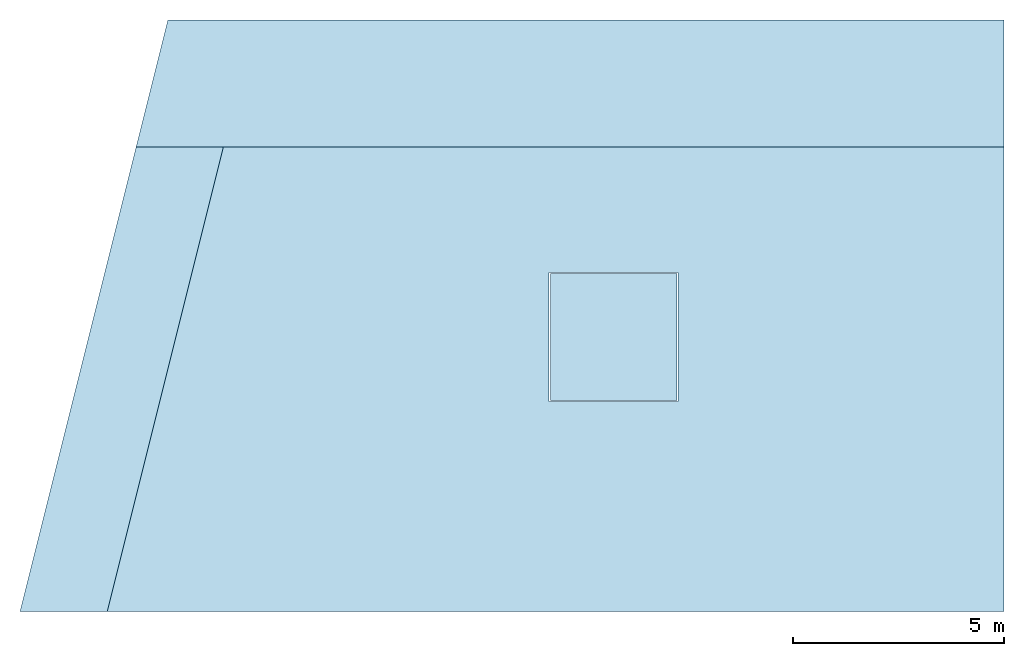
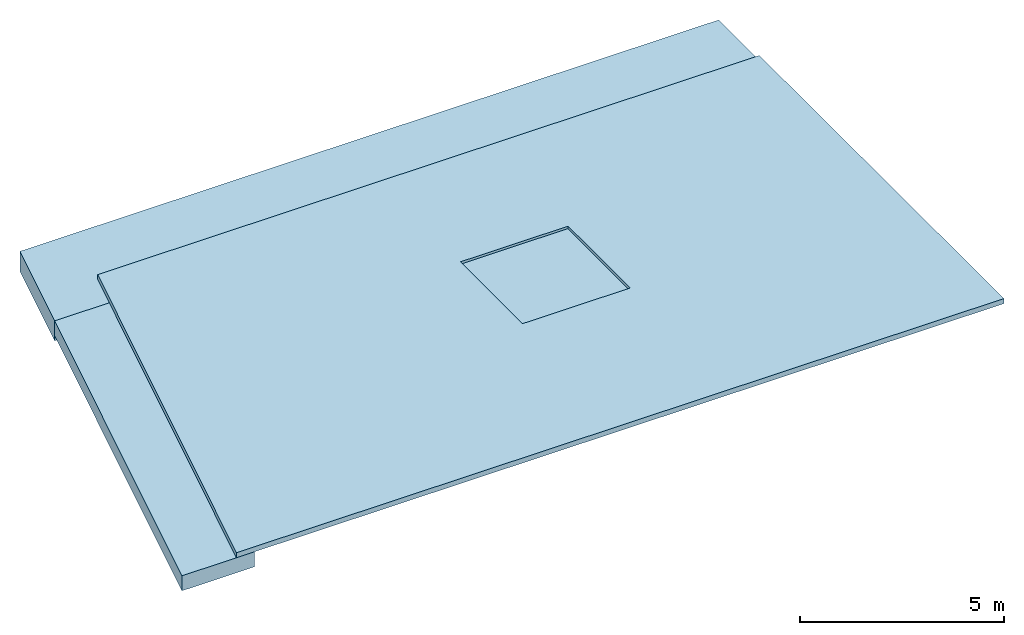
# One storey: 4 plates, 1 opening, 4 elements without a shape of their own.
"""IFC2X3 building model written with IfcOpenShell, lengths in millimetres."""

from ifc_helpers import new_model, entity, si_unit, converted_unit, frame, origin, origin_with_axes, place, context, project, spatial, polyline, outline, extrude, element, aggregate, save


model = new_model("IFC2X3")

# Units and contexts
model_context = context("Model", 3, precision=1e-09, world=origin_with_axes())
ifc_project = project(units=[si_unit("LENGTHUNIT", "METRE", prefix="MILLI"), si_unit("AREAUNIT", "SQUARE_METRE"), si_unit("VOLUMEUNIT", "CUBIC_METRE"), converted_unit("PLANEANGLEUNIT", "DEGREE", entity("IfcPlaneAngleMeasure", 0.01745329), si_unit("PLANEANGLEUNIT", "RADIAN"), dimensions=[0, 0, 0, 0, 0, 0, 0])], contexts=[model_context])

# Site, building, storey
site_placement = place(None, origin_with_axes())
site = spatial("IfcSite", under=ifc_project, at=site_placement, CompositionType="ELEMENT")
building_placement = place(site_placement, origin_with_axes())
building = spatial("IfcBuilding", under=site, at=building_placement, Name="Structure 1", CompositionType="ELEMENT")
storey_placement = place(building_placement, origin_with_axes())
storey = spatial("IfcBuildingStorey", under=building, at=storey_placement, Name="01 Concrete", CompositionType="ELEMENT", Elevation=0.0)

# Assembly, plate
assembly_1_placement = place(None, frame((-11296.164609607, 4500.0, -112.5), z_axis=(0.0, 0.0, 1.0), x_axis=(-0.242535625, -0.9701425, 0.0)))
assembly_1 = element("IfcElementAssembly", 1, at=assembly_1_placement, inside=storey, ObjectType="Steel Assembly", AssemblyPlace="FACTORY", PredefinedType="NOTDEFINED")
plate_1_placement = place(assembly_1_placement, origin_with_axes())
plate_1 = element("IfcPlate", 2, at=plate_1_placement, Name="Concrete_Foundation", ObjectType="Concrete_Foundation", context=model_context, shape_type="SweptSolid", body=[
    extrude(outline(polyline([(0.0, 0.0), (11338.540470449, 0.0), (10838.540470449, 2000.0), (-500.0, 2000.0), (0.0, 0.0)])), origin_with_axes(), (0.0, 0.0, 1.0), 450.0),
])
aggregate(assembly_1, [plate_1])

assembly_2_placement = place(None, frame((-11296.164609607, 4500.0, -262.5), z_axis=(0.0, 0.0, 1.0), x_axis=(1.0, 0.0, 0.0)))
assembly_2 = element("IfcElementAssembly", 3, at=assembly_2_placement, inside=storey, ObjectType="Steel Assembly", AssemblyPlace="FACTORY", PredefinedType="NOTDEFINED")
plate_2_placement = place(assembly_2_placement, origin_with_axes())
plate_2 = element("IfcPlate", 4, at=plate_2_placement, Name="Concrete_Foundation", ObjectType="Concrete_Foundation", context=model_context, shape_type="SweptSolid", body=[
    extrude(outline(polyline([(0.0, 0.0), (20530.817724866, 0.0), (20530.817724866, 3000.0), (750.0, 3000.0), (0.0, 0.0)])), origin_with_axes(), (0.0, 0.0, 1.0), 600.0),
])
aggregate(assembly_2, [plate_2])

# Assembly, plate, opening
assembly_3_placement = place(None, frame((-9500.0, 5500.0, 337.5), z_axis=(0.0, 0.0, 1.0), x_axis=(-0.242535625, -0.9701425, 0.0)))
assembly_3 = element("IfcElementAssembly", 5, at=assembly_3_placement, inside=storey, ObjectType="Steel Assembly", AssemblyPlace="FACTORY", PredefinedType="NOTDEFINED")
plate_3_placement = place(assembly_3_placement, origin_with_axes())
plate_3 = element("IfcPlate", 6, at=plate_3_placement, Name="Concrete_Slab", ObjectType="Concrete_Slab", context=model_context, shape_type="SweptSolid", body=[
    extrude(outline(polyline([(0.0, 0.0), (12369.316876853, 0.0), (7097.889198596, 21085.710713029), (-4543.820803148, 18175.283212593), (0.0, 0.0)])), origin_with_axes(), (0.0, 0.0, 1.0), 150.0),
])
opening_placement = place(plate_3_placement, frame((0.0, 0.0, -0.1), z_axis=(0.0, 0.0, 1.0), x_axis=(-0.242535625, 0.9701425, 0.0)))
element("IfcOpeningElement", 7, at=opening_placement, cuts=plate_3, ObjectType="Opening", context=model_context, shape_type="SweptSolid", body=[
    extrude(outline(polyline([(7974.999, -7025.001), (11025.001, -7025.001), (11025.001, -3974.999), (7974.999, -3974.999), (7974.999, -7025.001)])), origin(), (0.0, 0.0, 1.0), 150.2),
])
aggregate(assembly_3, [plate_3])

# Assembly, plate
assembly_4_placement = place(None, frame((1500.0, -1500.0, 437.5), z_axis=(0.0, 0.0, -1.0), x_axis=(-1.0, 0.0, 0.0)))
assembly_4 = element("IfcElementAssembly", 8, at=assembly_4_placement, inside=storey, ObjectType="Steel Assembly", AssemblyPlace="FACTORY", PredefinedType="NOTDEFINED")
plate_4_placement = place(assembly_4_placement, origin_with_axes())
plate_4 = element("IfcPlate", 9, at=plate_4_placement, Name="Concrete_Foundation", ObjectType="Concrete_Foundation", context=model_context, shape_type="SweptSolid", body=[
    extrude(outline(polyline([(0.0, 0.0), (3000.0, 0.0), (3000.0, 3000.0), (0.0, 3000.0), (0.0, 0.0)])), origin_with_axes(), (0.0, 0.0, 1.0), 1000.0),
])
aggregate(assembly_4, [plate_4])

save(model, "model.ifc")
